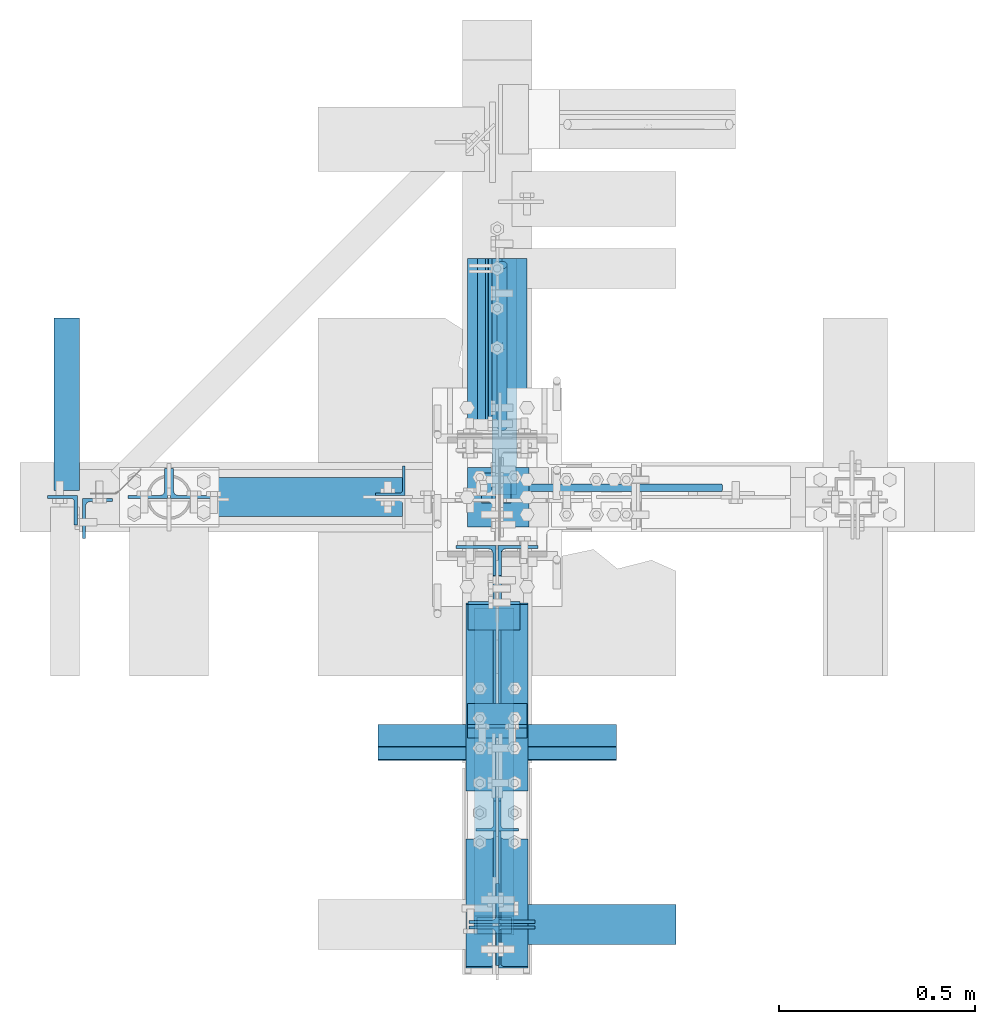
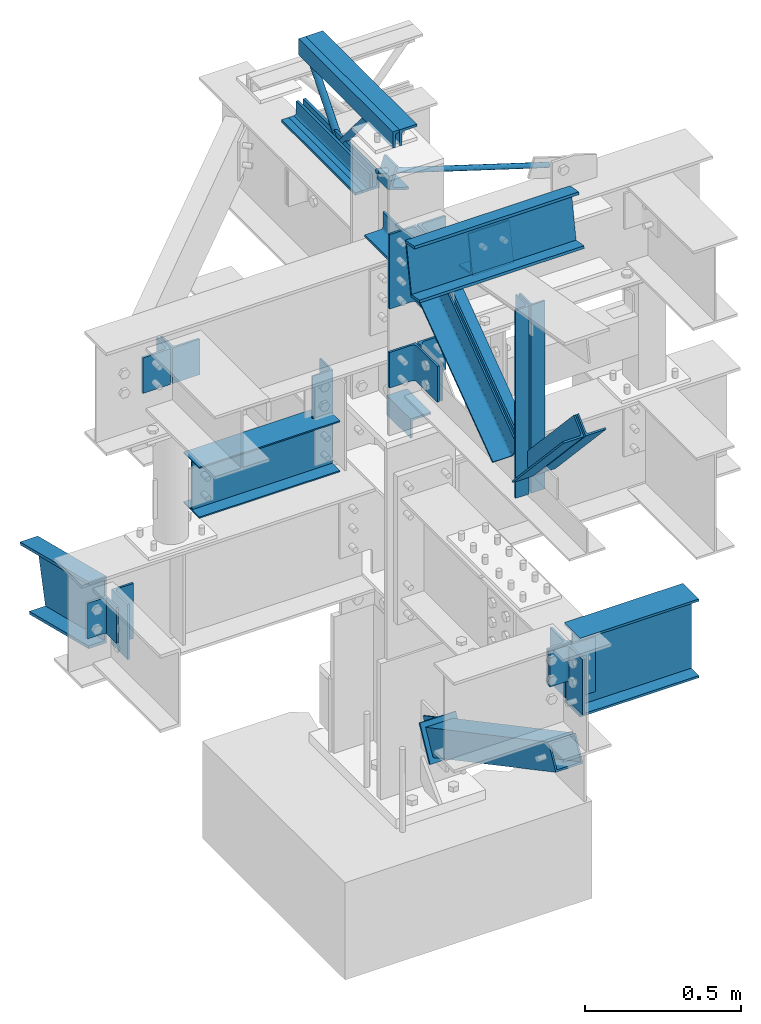
# Not in any storey, part 2 of 7: 31 members, 4 beams, 15 elements without a shape of their own.
"""IFC2X3 building model written with IfcOpenShell, lengths in inches."""

from ifc_helpers import new_model, entity, si_unit, converted_unit, frame, frame_2d, origin_with_axes, origin_2d_with_axis, place, context, project, spatial, hollow_rectangle, circle, i_section, l_section, t_section, u_section, transform_2d, derived_profile, extrude, clip, halfspace, source, transform, mapped, material, type_object, type_shapes, element, aggregate, save


model = new_model("IFC2X3")

# Units and contexts
model_context = context("Model", 3, precision=1e-05, world=origin_with_axes())
ifc_project = project(units=[converted_unit("LENGTHUNIT", "INCH", entity("IfcLengthMeasure", 25.4), si_unit("LENGTHUNIT", "METRE", prefix="MILLI"), dimensions=[1, 0, 0, 0, 0, 0, 0]), si_unit("PLANEANGLEUNIT", "RADIAN"), si_unit("MASSUNIT", "GRAM", prefix="KILO"), si_unit("TIMEUNIT", "SECOND"), si_unit("AREAUNIT", "SQUARE_METRE"), si_unit("PRESSUREUNIT", "PASCAL"), si_unit("FORCEUNIT", "NEWTON"), si_unit("THERMODYNAMICTEMPERATUREUNIT", "DEGREE_CELSIUS")], contexts=[model_context])

# Site, building
site_placement = place(None, origin_with_axes())
site = spatial("IfcSite", under=ifc_project, at=site_placement, CompositionType="ELEMENT")
building_placement = place(site_placement, origin_with_axes())
building = spatial("IfcBuilding", under=site, at=building_placement, Name="Building", CompositionType="ELEMENT")

# Assembly, members
assembly_1_placement = place(building_placement, frame((0.0, 0.0, 97.0), z_axis=(0.0, 0.0, -1.0), x_axis=(0.0, 1.0, 0.0)))
assembly_1 = element("IfcElementAssembly", 1, at=assembly_1_placement, inside=building, Name="M_40", PredefinedType="NOTDEFINED")
ifc_material_1 = material()
member_type_1 = type_object("IfcMemberType", Name="L2-1/2x2-1/2x3/8", PredefinedType="USERDEFINED", material=ifc_material_1)
shared_shape_1 = source(origin_with_axes(), model_context, "Body", "SweptSolid", [
    extrude(derived_profile(l_section(Depth=2.5, Width=2.5, Thickness=0.375, FilletRadius=0.3125, at=frame_2d((1.25, 1.25), x_axis=(1.0, 0.0))), transform_2d((0.0, 0.0), x_axis=(-1.0, 0.0), y_axis=(0.0, 1.0))), frame((0.0, 0.0, 0.0), z_axis=(1.0, 0.0, 0.0), x_axis=(0.0, 1.0, 0.0)), (0.0, 0.0, 1.0), 18.6250038146973),
])
type_shapes(member_type_1, [shared_shape_1])
member_1_placement = place(assembly_1_placement, frame((5.375, 0.5, 12.0), z_axis=(0.0, 0.0, -1.0), x_axis=(1.0, 0.0, 0.0)))
member_1 = element("IfcMember", 2, at=member_1_placement, type_object=member_type_1, Name="a33", ObjectType="Member", context=model_context, shape_type="MappedRepresentation", body=[
    mapped(shared_shape_1, transform((0.0, 0.0, 0.0), scale=1.0)),
])
member_type_2 = type_object("IfcMemberType", Name="L2-1/2x2-1/2x3/8", PredefinedType="USERDEFINED", material=ifc_material_1)
shared_shape_2 = source(origin_with_axes(), model_context, "Body", "SweptSolid", [
    extrude(l_section(Depth=2.5, Width=2.5, Thickness=0.375, FilletRadius=0.3125, at=frame_2d((1.25, 1.25), x_axis=(1.0, 0.0))), frame((0.0, 0.0, 0.0), z_axis=(1.0, 0.0, 0.0), x_axis=(0.0, 1.0, 0.0)), (0.0, 0.0, 1.0), 18.6250038146973),
])
type_shapes(member_type_2, [shared_shape_2])
member_2_placement = place(assembly_1_placement, frame((24.0000038146973, -0.5, 12.0), z_axis=(0.0, -1.0, 0.0), x_axis=(-1.0, 0.0, 0.0)))
member_2 = element("IfcMember", 3, at=member_2_placement, type_object=member_type_2, Name="a34", ObjectType="Member", context=model_context, shape_type="MappedRepresentation", body=[
    mapped(shared_shape_2, transform((0.0, 0.0, 0.0), scale=1.0)),
])
member_type_3 = type_object("IfcMemberType", Name="L2-1/2x2-1/2x3/8", PredefinedType="USERDEFINED", material=ifc_material_1)
shared_shape_3 = source(origin_with_axes(), model_context, "Body", "SweptSolid", [
    extrude(l_section(Depth=2.5, Width=2.5, Thickness=0.375, FilletRadius=0.3125, at=frame_2d((1.25, 1.25), x_axis=(1.0, 0.0))), frame((0.0, 0.0, 0.0), z_axis=(1.0, 0.0, 0.0), x_axis=(0.0, 1.0, 0.0)), (0.0, 0.0, 1.0), 23.7500038146973),
])
type_shapes(member_type_3, [shared_shape_3])
member_3_placement = place(assembly_1_placement, frame((0.25, 0.5, 0.0), z_axis=(0.0, 0.0, 1.0), x_axis=(1.0, 0.0, 0.0)))
member_3 = element("IfcMember", 4, at=member_3_placement, type_object=member_type_3, Name="a32", ObjectType="Member", context=model_context, shape_type="MappedRepresentation", body=[
    mapped(shared_shape_3, transform((0.0, 0.0, 0.0), scale=1.0)),
])
member_type_4 = type_object("IfcMemberType", Name="L2-1/2x2-1/2x3/8", PredefinedType="USERDEFINED", material=ifc_material_1)
shared_shape_4 = source(origin_with_axes(), model_context, "Body", "SweptSolid", [
    extrude(derived_profile(l_section(Depth=2.5, Width=2.5, Thickness=0.375, FilletRadius=0.3125, at=frame_2d((1.25, 1.25), x_axis=(1.0, 0.0))), transform_2d((0.0, 0.0), x_axis=(-1.0, 0.0), y_axis=(0.0, 1.0))), frame((0.0, 0.0, 0.0), z_axis=(1.0, 0.0, 0.0), x_axis=(0.0, 1.0, 0.0)), (0.0, 0.0, 1.0), 23.7500038146973),
])
type_shapes(member_type_4, [shared_shape_4])
member_4_placement = place(assembly_1_placement, frame((0.25, -0.5, 0.0), z_axis=(0.0, 0.0, 1.0), x_axis=(1.0, 0.0, 0.0)))
member_4 = element("IfcMember", 5, at=member_4_placement, type_object=member_type_4, Name="a6", ObjectType="Member", context=model_context, shape_type="MappedRepresentation", body=[
    mapped(shared_shape_4, transform((0.0, 0.0, 0.0), scale=1.0)),
])

# Assembly, member
assembly_2_placement = place(building_placement, frame((23.9999999999998, 0.9375, 83.0), z_axis=(0.0, 1.0, 0.0), x_axis=(-0.954479957764932, 0.0, 0.29827505800024)))
assembly_2 = element("IfcElementAssembly", 6, at=assembly_2_placement, inside=building, Name="4-7", PredefinedType="NOTDEFINED")
ifc_material_2 = material()
member_type_5 = type_object("IfcMemberType", Name="RB3/4", PredefinedType="BRACE", material=ifc_material_2)
shared_shape_5 = source(origin_with_axes(), model_context, "Body", "SweptSolid", [
    extrude(circle(Radius=0.375, at=origin_2d_with_axis()), frame((0.0, 0.0, 0.0), z_axis=(1.0, 0.0, 0.0), x_axis=(0.0, 1.0, 0.0)), (0.0, 0.0, 1.0), 26.1446208953857),
])
type_shapes(member_type_5, [shared_shape_5])
member_5_placement = place(assembly_2_placement, frame((1.50000073203523, 0.0, 0.0), z_axis=(0.0, 0.0, -1.0), x_axis=(1.0, 0.0, 0.0)))
member_5 = element("IfcMember", 7, at=member_5_placement, type_object=member_type_5, Name="rb5", ObjectType="Vertical brace", context=model_context, shape_type="MappedRepresentation", body=[
    mapped(shared_shape_5, transform((0.0, 0.0, 0.0), scale=1.0)),
])
aggregate(assembly_2, [member_5])

# Assembly, beam
assembly_3_placement = place(building_placement, frame((0.0, -3.0, 80.0), z_axis=(0.0, 0.0, -1.0), x_axis=(0.0, 1.0, 0.0)))
assembly_3 = element("IfcElementAssembly", 8, at=assembly_3_placement, inside=building, Name="2-9", PredefinedType="NOTDEFINED")
beam_type_1 = type_object("IfcBeamType", Name="L3x3x3/8", PredefinedType="USERDEFINED", material=ifc_material_1)
shared_shape_6 = source(origin_with_axes(), model_context, "Body", "SweptSolid", [
    extrude(derived_profile(l_section(Depth=3.0, Width=3.0, Thickness=0.375, FilletRadius=0.3125, at=frame_2d((1.5, 1.5), x_axis=(1.0, 0.0))), transform_2d((0.0, 0.0), x_axis=(-1.0, 0.0), y_axis=(0.0, 1.0))), frame((0.0, 0.0, 0.0), z_axis=(1.0, 0.0, 0.0), x_axis=(0.0, 1.0, 0.0)), (0.0, 0.0, 1.0), 6.0),
])
type_shapes(beam_type_1, [shared_shape_6])
beam_1_placement = place(assembly_3_placement, frame((0.0, 0.0, 0.0), z_axis=(0.0, 0.0, -1.0), x_axis=(1.0, 0.0, 0.0)))
beam_1 = element("IfcBeam", 9, at=beam_1_placement, type_object=beam_type_1, Name="a27", ObjectType="Member", context=model_context, shape_type="MappedRepresentation", body=[
    mapped(shared_shape_6, transform((0.0, 0.0, 0.0), scale=1.0)),
])
aggregate(assembly_3, [beam_1])

# Assembly, member
assembly_4_placement = place(building_placement, frame((0.0, 0.0, 21.0), z_axis=(0.0, -1.0, 0.0), x_axis=(0.0, 0.0, 1.0)))
assembly_4 = element("IfcElementAssembly", 10, at=assembly_4_placement, inside=building, Name="1-2", PredefinedType="NOTDEFINED")
member_type_6 = type_object("IfcMemberType", Name="L3x3x5/16", PredefinedType="USERDEFINED", material=ifc_material_1)
shared_shape_7 = source(origin_with_axes(), model_context, "Body", "SweptSolid", [
    extrude(derived_profile(l_section(Depth=3.0, Width=3.0, Thickness=0.3125, FilletRadius=0.3125, at=frame_2d((1.5, 1.5), x_axis=(1.0, 0.0))), transform_2d((0.0, 0.0), x_axis=(-1.0, 0.0), y_axis=(0.0, 1.0))), frame((0.0, 0.0, 0.0), z_axis=(1.0, 0.0, 0.0), x_axis=(0.0, 1.0, 0.0)), (0.0, 0.0, 1.0), 6.0),
])
type_shapes(member_type_6, [shared_shape_7])
member_6_placement = place(assembly_4_placement, frame((33.5, -0.207499995827675, -3.0), z_axis=(0.0, -1.0, 0.0), x_axis=(0.0, 0.0, 1.0)))
member_6 = element("IfcMember", 11, at=member_6_placement, type_object=member_type_6, Name="a29", ObjectType="Column", context=model_context, shape_type="MappedRepresentation", body=[
    mapped(shared_shape_7, transform((0.0, 0.0, 0.0), scale=1.0)),
])
aggregate(assembly_4, [member_6])

assembly_5_placement = place(building_placement, frame((0.0, 0.0, 54.5), z_axis=(0.0, -1.0, 0.0), x_axis=(0.0, 0.0, 1.0)))
assembly_5 = element("IfcElementAssembly", 12, at=assembly_5_placement, inside=building, Name="1-3", PredefinedType="NOTDEFINED")
member_type_7 = type_object("IfcMemberType", Name="L3-1/2x3x3/8", PredefinedType="USERDEFINED", material=ifc_material_1)
shared_shape_8 = source(origin_with_axes(), model_context, "Body", "SweptSolid", [
    extrude(l_section(Depth=3.5, Width=3.0, Thickness=0.375, FilletRadius=0.4375, at=frame_2d((1.5, 1.75), x_axis=(1.0, 0.0))), frame((0.0, 0.0, 0.0), z_axis=(1.0, 0.0, 0.0), x_axis=(0.0, 1.0, 0.0)), (0.0, 0.0, 1.0), 3.0),
])
type_shapes(member_type_7, [shared_shape_8])
member_7_placement = place(assembly_5_placement, frame((34.3969296478214, 1.56886904721182, -2.43749999809271), z_axis=(0.952395799643279, -0.304864299028012, 0.0), x_axis=(0.0, 0.0, 1.0)))
member_7 = element("IfcMember", 13, at=member_7_placement, type_object=member_type_7, Name="a24", ObjectType="Column", context=model_context, shape_type="MappedRepresentation", body=[
    mapped(shared_shape_8, transform((0.0, 0.0, 0.0), scale=1.0)),
])
aggregate(assembly_5, [member_7])

assembly_6_placement = place(building_placement, frame((0.0, 0.0, 46.0), z_axis=(0.0, 0.0, 1.0), x_axis=(-1.0, 0.0, 0.0)))
assembly_6 = element("IfcElementAssembly", 14, at=assembly_6_placement, inside=building, Name="2-4", PredefinedType="NOTDEFINED")
member_type_8 = type_object("IfcMemberType", Name="L4x3x5/16", PredefinedType="USERDEFINED", material=ifc_material_1)
shared_shape_9 = source(origin_with_axes(), model_context, "Body", "SweptSolid", [
    extrude(l_section(Depth=4.0, Width=3.0, Thickness=0.3125, FilletRadius=0.4375, at=frame_2d((1.5, 2.0), x_axis=(1.0, 0.0))), frame((0.0, 0.0, 0.0), z_axis=(1.0, 0.0, 0.0), x_axis=(0.0, 1.0, 0.0)), (0.0, 0.0, 1.0), 8.5),
])
type_shapes(member_type_8, [shared_shape_9])
member_8_placement = place(assembly_6_placement, frame((41.7179999947548, 0.14750000834465, -4.75), z_axis=(0.0, 1.0, 0.0), x_axis=(0.0, 0.0, -1.0)))
member_8 = element("IfcMember", 15, at=member_8_placement, type_object=member_type_8, Name="a1", ObjectType="Beam", context=model_context, shape_type="MappedRepresentation", body=[
    mapped(shared_shape_9, transform((0.0, 0.0, 0.0), scale=1.0)),
])
aggregate(assembly_6, [member_8])

# Assembly, beam
assembly_7_placement = place(building_placement, frame((-9.25, 0.0, 57.0), z_axis=(0.0, 0.0, 1.0), x_axis=(-1.0, 0.0, 0.0)))
assembly_7 = element("IfcElementAssembly", 16, at=assembly_7_placement, inside=building, Name="3-13", PredefinedType="NOTDEFINED")
ifc_material_3 = material()
beam_type_2 = type_object("IfcBeamType", Name="W8x10", PredefinedType="BEAM", material=ifc_material_3)
shared_shape_10 = source(origin_with_axes(), model_context, "Body", "SweptSolid", [
    extrude(i_section(OverallWidth=3.94, OverallDepth=7.89, WebThickness=0.17, FlangeThickness=0.205, at=frame_2d((0.0, -3.945), x_axis=(1.0, 0.0))), frame((0.0, 0.0, 0.0), z_axis=(1.0, 0.0, 0.0), x_axis=(0.0, 1.0, 0.0)), (0.0, 0.0, 1.0), 20.5),
])
type_shapes(beam_type_2, [shared_shape_10])
beam_2_placement = place(assembly_7_placement, frame((0.25, 0.0, 0.0), z_axis=(0.0, 0.0, 1.0), x_axis=(1.0, 0.0, 0.0)))
beam_2 = element("IfcBeam", 17, at=beam_2_placement, type_object=beam_type_2, Name="w8", ObjectType="Beam", context=model_context, shape_type="MappedRepresentation", body=[
    mapped(shared_shape_10, transform((0.0, 0.0, 0.0), scale=1.0)),
])
aggregate(assembly_7, [beam_2])

# Assembly, member
assembly_8_placement = place(building_placement, frame((-9.25, 0.0, 50.0), z_axis=(-1.0, 0.0, 0.0), x_axis=(0.0, 0.0, 1.0)))
assembly_8 = element("IfcElementAssembly", 18, at=assembly_8_placement, inside=building, Name="4-5", PredefinedType="NOTDEFINED")
member_type_9 = type_object("IfcMemberType", Name="L3x3x1/4", PredefinedType="USERDEFINED", material=ifc_material_1)
shared_shape_11 = source(origin_with_axes(), model_context, "Body", "SweptSolid", [
    extrude(l_section(Depth=3.0, Width=3.0, Thickness=0.25, FilletRadius=0.3125, at=frame_2d((1.5, 1.5), x_axis=(1.0, 0.0))), frame((0.0, 0.0, 0.0), z_axis=(1.0, 0.0, 0.0), x_axis=(0.0, 1.0, 0.0)), (0.0, 0.0, 1.0), 13.5),
])
type_shapes(member_type_9, [shared_shape_11])
member_9_placement = place(assembly_8_placement, frame((13.5, 0.156249999999994, 0.0), z_axis=(0.0, 1.0, 0.0), x_axis=(-1.0, 0.0, 0.0)))
member_9 = element("IfcMember", 19, at=member_9_placement, type_object=member_type_9, Name="a36", ObjectType="Column", context=model_context, shape_type="MappedRepresentation", body=[
    mapped(shared_shape_11, transform((0.0, 0.0, 0.0), scale=1.0)),
])
aggregate(assembly_8, [member_9])

# Assembly, members
assembly_9_placement = place(building_placement, frame((-42.0, 0.0, 43.0), z_axis=(0.0, 0.242535628120103, 0.970142499374389), x_axis=(0.0, 0.970142499374388, -0.242535628120103)))
assembly_9 = element("IfcElementAssembly", 20, at=assembly_9_placement, inside=building, Name="3-8", PredefinedType="NOTDEFINED")
member_type_10 = type_object("IfcMemberType", Name="L3x3x5/16", PredefinedType="USERDEFINED", material=ifc_material_1)
shared_shape_12 = source(origin_with_axes(), model_context, "Body", "SweptSolid", [
    extrude(derived_profile(l_section(Depth=3.0, Width=3.0, Thickness=0.3125, FilletRadius=0.3125, at=frame_2d((1.5, 1.5), x_axis=(1.0, 0.0))), transform_2d((0.0, 0.0), x_axis=(-1.0, 0.0), y_axis=(0.0, 1.0))), frame((0.0, 0.0, 0.0), z_axis=(1.0, 0.0, 0.0), x_axis=(0.0, 1.0, 0.0)), (0.0, 0.0, 1.0), 5.5),
])
type_shapes(member_type_10, [shared_shape_12])
member_10_placement = place(assembly_9_placement, frame((0.848874774117084, 0.239999994635582, -2.62241641770861), z_axis=(0.0, 1.0, 0.0), x_axis=(0.242535628120103, 0.0, -0.970142499374389)))
member_10 = element("IfcMember", 21, at=member_10_placement, type_object=member_type_10, Name="a2", ObjectType="Beam", context=model_context, shape_type="MappedRepresentation", body=[
    mapped(shared_shape_12, transform((0.0, 0.0, 0.0), scale=1.0)),
])
ifc_material_4 = material()
member_type_11 = type_object("IfcMemberType", Name="C10x15.3", PredefinedType="USERDEFINED", material=ifc_material_4)
shared_shape_13 = source(origin_with_axes(), model_context, "Body", "Clipping", [
    clip(extrude(u_section(Depth=10.0, FlangeWidth=2.6, WebThickness=0.24, FlangeThickness=0.436, at=frame_2d((1.3, -5.0), x_axis=(1.0, 0.0))), frame((0.0, 0.0, 0.0), z_axis=(1.0, 0.0, 0.0), x_axis=(0.0, 1.0, 0.0)), (0.0, 0.0, 1.0), 17.8453178405762), halfspace(frame((0.0, 0.0, 0.0), z_axis=(-0.97013, 0.0, -0.2426), x_axis=(-0.2426, 0.0, 0.97013)), False)),
])
type_shapes(member_type_11, [shared_shape_13])
member_11_placement = place(assembly_9_placement, frame((0.708658754825592, 0.0, 0.0), z_axis=(0.0, 0.0, 1.0), x_axis=(1.0, 0.0, 0.0)))
member_11 = element("IfcMember", 22, at=member_11_placement, type_object=member_type_11, Name="c1", ObjectType="Beam", context=model_context, shape_type="MappedRepresentation", body=[
    mapped(shared_shape_13, transform((0.0, 0.0, 0.0), scale=1.0)),
])
aggregate(assembly_9, [member_10, member_11])

assembly_10_placement = place(building_placement, frame((0.0, -43.0, 46.0), z_axis=(0.0, 0.0, 1.0), x_axis=(1.0, 0.0, 0.0)))
assembly_10 = element("IfcElementAssembly", 23, at=assembly_10_placement, inside=building, Name="3-6", PredefinedType="NOTDEFINED")
member_type_12 = type_object("IfcMemberType", Name="L4x3x5/16", PredefinedType="USERDEFINED", material=ifc_material_1)
shared_shape_14 = source(origin_with_axes(), model_context, "Body", "SweptSolid", [
    extrude(derived_profile(l_section(Depth=4.0, Width=3.0, Thickness=0.3125, FilletRadius=0.4375, at=frame_2d((1.5, 2.0), x_axis=(1.0, 0.0))), transform_2d((0.0, 0.0), x_axis=(-1.0, 0.0), y_axis=(0.0, 1.0))), frame((0.0, 0.0, 0.0), z_axis=(1.0, 0.0, 0.0), x_axis=(0.0, 1.0, 0.0)), (0.0, 0.0, 1.0), 5.5),
])
type_shapes(member_type_12, [shared_shape_14])
member_12_placement = place(assembly_10_placement, frame((0.1875, -0.117499999701977, -7.25), z_axis=(0.0, -1.0, 0.0), x_axis=(0.0, 0.0, 1.0)))
member_12 = element("IfcMember", 24, at=member_12_placement, type_object=member_type_12, Name="a12", ObjectType="Beam", context=model_context, shape_type="MappedRepresentation", body=[
    mapped(shared_shape_14, transform((0.0, 0.0, 0.0), scale=1.0)),
])
member_13_placement = place(assembly_10_placement, frame((0.1875, 0.117499999701977, -1.75), z_axis=(0.0, 1.0, 0.0), x_axis=(0.0, 0.0, -1.0)))
member_13 = element("IfcMember", 25, at=member_13_placement, type_object=member_type_12, Name="a12", ObjectType="Beam", context=model_context, shape_type="MappedRepresentation", body=[
    mapped(shared_shape_14, transform((0.0, 0.0, 0.0), scale=1.0)),
])

assembly_11_placement = place(building_placement, frame((-33.0, 0.0, 77.0), z_axis=(0.0, 0.0, 1.0), x_axis=(0.0, -1.0, 0.0)))
assembly_11 = element("IfcElementAssembly", 26, at=assembly_11_placement, inside=building, Name="3-10", PredefinedType="NOTDEFINED")
member_14_placement = place(assembly_11_placement, frame((0.125, -0.144999995827675, -7.25), z_axis=(0.0, -1.0, 0.0), x_axis=(0.0, 0.0, 1.0)))
member_14 = element("IfcMember", 27, at=member_14_placement, type_object=member_type_12, Name="a31", ObjectType="Beam", context=model_context, shape_type="MappedRepresentation", body=[
    mapped(shared_shape_14, transform((0.0, 0.0, 0.0), scale=1.0)),
])
member_15_placement = place(assembly_11_placement, frame((0.125, 0.144999995827675, -1.75), z_axis=(0.0, 1.0, 0.0), x_axis=(0.0, 0.0, -1.0)))
member_15 = element("IfcMember", 28, at=member_15_placement, type_object=member_type_12, Name="a31", ObjectType="Beam", context=model_context, shape_type="MappedRepresentation", body=[
    mapped(shared_shape_14, transform((0.0, 0.0, 0.0), scale=1.0)),
])
aggregate(assembly_11, [member_14, member_15])

# Beam
beam_type_3 = type_object("IfcBeamType", Name="W12x19", PredefinedType="BEAM", material=ifc_material_3)
shared_shape_15 = source(origin_with_axes(), model_context, "Body", "SweptSolid", [
    extrude(i_section(OverallWidth=4.005, OverallDepth=12.16, WebThickness=0.235, FlangeThickness=0.35, at=frame_2d((0.0, -6.08), x_axis=(1.0, 0.0))), frame((0.0, 0.0, 0.0), z_axis=(1.0, 0.0, 0.0), x_axis=(0.0, 1.0, 0.0)), (0.0, 0.0, 1.0), 17.3125),
])
type_shapes(beam_type_3, [shared_shape_15])
beam_3_placement = place(assembly_10_placement, frame((0.6875, 0.0, 0.0), z_axis=(0.0, 0.0, 1.0), x_axis=(1.0, 0.0, 0.0)))
beam_3 = element("IfcBeam", 29, at=beam_3_placement, type_object=beam_type_3, Name="w15", ObjectType="Beam", context=model_context, shape_type="MappedRepresentation", body=[
    mapped(shared_shape_15, transform((0.0, 0.0, 0.0), scale=1.0)),
])

aggregate(assembly_10, [member_12, member_13, beam_3])

# Assembly, members
assembly_12_placement = place(building_placement, frame((0.0, -43.0, 46.0), z_axis=(0.0, 0.0, 1.0), x_axis=(-1.0, 0.0, 0.0)))
assembly_12 = element("IfcElementAssembly", 30, at=assembly_12_placement, inside=building, Name="3-5", PredefinedType="NOTDEFINED")
member_type_13 = type_object("IfcMemberType", Name="L4x4x5/16", PredefinedType="USERDEFINED", material=ifc_material_1)
shared_shape_16 = source(origin_with_axes(), model_context, "Body", "SweptSolid", [
    extrude(derived_profile(l_section(Depth=4.0, Width=4.0, Thickness=0.3125, FilletRadius=0.375, at=frame_2d((2.0, 2.0), x_axis=(1.0, 0.0))), transform_2d((0.0, 0.0), x_axis=(-1.0, 0.0), y_axis=(0.0, 1.0))), frame((0.0, 0.0, 0.0), z_axis=(1.0, 0.0, 0.0), x_axis=(0.0, 1.0, 0.0)), (0.0, 0.0, 1.0), 8.5),
])
type_shapes(member_type_13, [shared_shape_16])
member_16_placement = place(assembly_12_placement, frame((0.1875, -0.127499997615814, -10.25), z_axis=(0.0, -1.0, 0.0), x_axis=(0.0, 0.0, 1.0)))
member_16 = element("IfcMember", 31, at=member_16_placement, type_object=member_type_13, Name="a9", ObjectType="Beam", context=model_context, shape_type="MappedRepresentation", body=[
    mapped(shared_shape_16, transform((0.0, 0.0, 0.0), scale=1.0)),
])
member_17_placement = place(assembly_12_placement, frame((0.1875, 0.127499997615814, -1.75), z_axis=(0.0, 1.0, 0.0), x_axis=(0.0, 0.0, -1.0)))
member_17 = element("IfcMember", 32, at=member_17_placement, type_object=member_type_13, Name="a9", ObjectType="Beam", context=model_context, shape_type="MappedRepresentation", body=[
    mapped(shared_shape_16, transform((0.0, 0.0, 0.0), scale=1.0)),
])
aggregate(assembly_12, [member_16, member_17])

assembly_13_placement = place(building_placement, frame((-0.302501678466797, -6.35499954223631, 7.97817420959473), z_axis=(0.0, 0.470283939984076, 0.882515164624979), x_axis=(0.0, -0.882515164624978, 0.470283939984076)))
assembly_13 = element("IfcElementAssembly", 33, at=assembly_13_placement, inside=building, Name="4-6", PredefinedType="NOTDEFINED")
ifc_material_5 = material()
member_type_14 = type_object("IfcMemberType", Name="WT4x9", PredefinedType="BRACE", material=ifc_material_5)
shared_shape_17 = source(origin_with_axes(), model_context, "Body", "SweptSolid", [
    extrude(t_section(Depth=4.07, FlangeWidth=5.25, WebThickness=0.23, FlangeThickness=0.33, at=frame_2d((0.0, -2.035), x_axis=(1.0, 0.0))), frame((0.0, 0.0, 0.0), z_axis=(1.0, 0.0, 0.0), x_axis=(0.0, 1.0, 0.0)), (0.0, 0.0, 1.0), 5.50000143051147),
])
type_shapes(member_type_14, [shared_shape_17])
member_18_placement = place(assembly_13_placement, frame((6.49234243351773, 0.0, 2.75002784669811), z_axis=(1.0, 0.0, 0.0), x_axis=(0.0, 0.0, -1.0)))
member_18 = element("IfcMember", 34, at=member_18_placement, type_object=member_type_14, Name="wt1", ObjectType="Vertical brace", context=model_context, shape_type="MappedRepresentation", body=[
    mapped(shared_shape_17, transform((0.0, 0.0, 0.0), scale=1.0)),
])
ifc_material_6 = material()
member_type_15 = type_object("IfcMemberType", Name="TS4x4x1/4", PredefinedType="BRACE", material=ifc_material_6)
shared_shape_18 = source(origin_with_axes(), model_context, "Body", "SweptSolid", [
    extrude(hollow_rectangle(XDim=4.0, YDim=4.0, WallThickness=0.25, at=origin_2d_with_axis()), frame((0.0, 0.0, 0.0), z_axis=(1.0, 0.0, 0.0), x_axis=(0.0, 1.0, 0.0)), (0.0, 0.0, 1.0), 35.1264915466309),
])
type_shapes(member_type_15, [shared_shape_18])
member_19_placement = place(assembly_13_placement, frame((6.49999999999999, 0.0, 0.0), z_axis=(0.0, 0.0, 1.0), x_axis=(1.0, 0.0, 0.0)))
member_19 = element("IfcMember", 35, at=member_19_placement, type_object=member_type_15, Name="ts5", ObjectType="Vertical brace", context=model_context, shape_type="MappedRepresentation", body=[
    mapped(shared_shape_18, transform((0.0, 0.0, 0.0), scale=1.0)),
])
aggregate(assembly_13, [member_18, member_19])

assembly_14_placement = place(building_placement, frame((0.0, -47.9999999999999, 94.0), z_axis=(0.0, 0.17437043319647, 0.984680126755321), x_axis=(0.0, 0.98468012675532, -0.17437043319647)))
assembly_14 = element("IfcElementAssembly", 36, at=assembly_14_placement, inside=building, Name="4-8", PredefinedType="NOTDEFINED")
member_type_16 = type_object("IfcMemberType", Name="L4x3x5/16", PredefinedType="USERDEFINED", material=ifc_material_1)
shared_shape_19 = source(origin_with_axes(), model_context, "Body", "SweptSolid", [
    extrude(l_section(Depth=4.0, Width=3.0, Thickness=0.3125, FilletRadius=0.4375, at=frame_2d((1.5, 2.0), x_axis=(1.0, 0.0))), frame((0.0, 0.0, 0.0), z_axis=(1.0, 0.0, 0.0), x_axis=(0.0, 1.0, 0.0)), (0.0, 0.0, 1.0), 11.5),
])
type_shapes(member_type_16, [shared_shape_19])
member_20_placement = place(assembly_14_placement, frame((45.9081465219534, -0.107503354549408, -11.9277075718198), z_axis=(0.0, -1.0, 0.0), x_axis=(-0.17437043319647, 0.0, 0.984680126755321)))
member_20 = element("IfcMember", 37, at=member_20_placement, type_object=member_type_16, Name="a16", ObjectType="Beam", context=model_context, shape_type="MappedRepresentation", body=[
    mapped(shared_shape_19, transform((0.0, 0.0, 0.0), scale=1.0)),
])
member_21_placement = place(assembly_14_placement, frame((43.9028865401939, 0.122502744197844, -0.603886114133672), z_axis=(0.0, 1.0, 0.0), x_axis=(0.17437043319647, 0.0, -0.984680126755321)))
member_21 = element("IfcMember", 38, at=member_21_placement, type_object=member_type_16, Name="a16", ObjectType="Beam", context=model_context, shape_type="MappedRepresentation", body=[
    mapped(shared_shape_19, transform((0.0, 0.0, 0.0), scale=1.0)),
])
member_type_17 = type_object("IfcMemberType", Name="L6x3-1/2x5/16", PredefinedType="USERDEFINED", material=ifc_material_1)
shared_shape_20 = source(origin_with_axes(), model_context, "Body", "SweptSolid", [
    extrude(derived_profile(l_section(Depth=6.0, Width=3.5, Thickness=0.3125, FilletRadius=0.5, at=frame_2d((1.75, 3.0), x_axis=(1.0, 0.0))), transform_2d((0.0, 0.0), x_axis=(-1.0, 0.0), y_axis=(0.0, 1.0))), frame((0.0, 0.0, 0.0), z_axis=(1.0, 0.0, 0.0), x_axis=(0.0, 1.0, 0.0)), (0.0, 0.0, 1.0), 6.0),
])
type_shapes(member_type_17, [shared_shape_20])
member_22_placement = place(assembly_14_placement, frame((24.0000007250116, 3.0, 0.687500208160415), z_axis=(0.0, 0.0, 1.0), x_axis=(0.0, -1.0, 0.0)))
member_22 = element("IfcMember", 39, at=member_22_placement, type_object=member_type_17, Name="a25", ObjectType="Beam", context=model_context, shape_type="MappedRepresentation", body=[
    mapped(shared_shape_20, transform((0.0, 0.0, 0.0), scale=1.0)),
])
member_type_18 = type_object("IfcMemberType", Name="L6x4x5/16", PredefinedType="USERDEFINED", material=ifc_material_1)
shared_shape_21 = source(origin_with_axes(), model_context, "Body", "SweptSolid", [
    extrude(l_section(Depth=6.0, Width=4.0, Thickness=0.3125, FilletRadius=0.5, at=frame_2d((2.0, 3.0), x_axis=(1.0, 0.0))), frame((0.0, 0.0, 0.0), z_axis=(1.0, 0.0, 0.0), x_axis=(0.0, 1.0, 0.0)), (0.0, 0.0, 1.0), 5.5),
])
type_shapes(member_type_18, [shared_shape_21])
member_23_placement = place(assembly_14_placement, frame((48.0431350813066, 0.115000002086163, -23.9267525398229), z_axis=(-0.98468012675532, 0.0, -0.17437043319647), x_axis=(-0.17437043319647, 0.0, 0.984680126755321)))
member_23 = element("IfcMember", 40, at=member_23_placement, type_object=member_type_18, Name="a26", ObjectType="Beam", context=model_context, shape_type="MappedRepresentation", body=[
    mapped(shared_shape_21, transform((0.0, 0.0, 0.0), scale=1.0)),
])
member_24_placement = place(assembly_14_placement, frame((47.084097698726, -0.115000002086165, -18.5110118426687), z_axis=(-0.98468012675532, 0.0, -0.17437043319647), x_axis=(0.17437043319647, 0.0, -0.984680126755321)))
member_24 = element("IfcMember", 41, at=member_24_placement, type_object=member_type_18, Name="a26", ObjectType="Beam", context=model_context, shape_type="MappedRepresentation", body=[
    mapped(shared_shape_21, transform((0.0, 0.0, 0.0), scale=1.0)),
])
member_type_19 = type_object("IfcMemberType", Name="L3x3x1/4", PredefinedType="USERDEFINED", material=ifc_material_1)
shared_shape_22 = source(origin_with_axes(), model_context, "Body", "SweptSolid", [
    extrude(derived_profile(l_section(Depth=3.0, Width=3.0, Thickness=0.25, FilletRadius=0.3125, at=frame_2d((1.5, 1.5), x_axis=(1.0, 0.0))), transform_2d((0.0, 0.0), x_axis=(-1.0, 0.0), y_axis=(0.0, 1.0))), frame((0.0, 0.0, 0.0), z_axis=(1.0, 0.0, 0.0), x_axis=(0.0, 1.0, 0.0)), (0.0, 0.0, 1.0), 23.2499942779541),
])
type_shapes(member_type_19, [shared_shape_22])
member_25_placement = place(assembly_14_placement, frame((23.3610050291526, -0.125, -25.3745518841465), z_axis=(0.0, -1.0, 0.0), x_axis=(0.691079008354412, 0.0, 0.72277922231611)))
member_25 = element("IfcMember", 42, at=member_25_placement, type_object=member_type_19, Name="a4", ObjectType="Beam", context=model_context, shape_type="MappedRepresentation", body=[
    mapped(shared_shape_22, transform((0.0, 0.0, 0.0), scale=1.0)),
])
member_26_placement = place(assembly_14_placement, frame((39.4285880667948, 0.125, -8.56993931105693), z_axis=(0.0, 1.0, 0.0), x_axis=(-0.691079008354409, 0.0, -0.722779222316112)))
member_26 = element("IfcMember", 43, at=member_26_placement, type_object=member_type_19, Name="a4", ObjectType="Beam", context=model_context, shape_type="MappedRepresentation", body=[
    mapped(shared_shape_22, transform((0.0, 0.0, 0.0), scale=1.0)),
])
member_type_20 = type_object("IfcMemberType", Name="L3x2x1/4", PredefinedType="USERDEFINED", material=ifc_material_1)
shared_shape_23 = source(origin_with_axes(), model_context, "Body", "SweptSolid", [
    extrude(l_section(Depth=3.0, Width=2.0, Thickness=0.25, FilletRadius=0.3125, at=frame_2d((1.0, 1.5), x_axis=(1.0, 0.0))), frame((0.0, 0.0, 0.0), z_axis=(1.0, 0.0, 0.0), x_axis=(0.0, 1.0, 0.0)), (0.0, 0.0, 1.0), 29.0),
])
type_shapes(member_type_20, [shared_shape_23])
member_27_placement = place(assembly_14_placement, frame((19.8574554988699, -0.134998321533203, -29.3839910943416), z_axis=(0.98468012675532, 0.0, 0.17437043319647), x_axis=(-0.17437043319647, 0.0, 0.984680126755321)))
member_27 = element("IfcMember", 44, at=member_27_placement, type_object=member_type_20, Name="a21", ObjectType="Beam", context=model_context, shape_type="MappedRepresentation", body=[
    mapped(shared_shape_23, transform((0.0, 0.0, 0.0), scale=1.0)),
])
member_28_placement = place(assembly_14_placement, frame((14.8007129361722, 0.134998321533203, -0.828267418437292), z_axis=(0.98468012675532, 0.0, 0.17437043319647), x_axis=(0.17437043319647, 0.0, -0.984680126755321)))
member_28 = element("IfcMember", 45, at=member_28_placement, type_object=member_type_20, Name="a21", ObjectType="Beam", context=model_context, shape_type="MappedRepresentation", body=[
    mapped(shared_shape_23, transform((0.0, 0.0, 0.0), scale=1.0)),
])
member_type_21 = type_object("IfcMemberType", Name="L3x3x1/4", PredefinedType="USERDEFINED", material=ifc_material_1)
shared_shape_24 = source(origin_with_axes(), model_context, "Body", "SweptSolid", [
    extrude(derived_profile(l_section(Depth=3.0, Width=3.0, Thickness=0.25, FilletRadius=0.3125, at=frame_2d((1.5, 1.5), x_axis=(1.0, 0.0))), transform_2d((0.0, 0.0), x_axis=(-1.0, 0.0), y_axis=(0.0, 1.0))), frame((0.0, 0.0, 0.0), z_axis=(1.0, 0.0, 0.0), x_axis=(0.0, 1.0, 0.0)), (0.0, 0.0, 1.0), 18.8750019073486),
])
type_shapes(member_type_21, [shared_shape_24])
member_29_placement = place(assembly_14_placement, frame((3.24754149855325, -0.125, -14.8378072761302), z_axis=(0.0, -1.0, 0.0), x_axis=(0.79698579420595, 0.0, -0.603998049528234)))
member_29 = element("IfcMember", 46, at=member_29_placement, type_object=member_type_21, Name="a30", ObjectType="Beam", context=model_context, shape_type="MappedRepresentation", body=[
    mapped(shared_shape_24, transform((0.0, 0.0, 0.0), scale=1.0)),
])
member_30_placement = place(assembly_14_placement, frame((18.2906509515737, 0.125, -26.2382717407428), z_axis=(0.0, 1.0, 0.0), x_axis=(-0.796985794205948, 0.0, 0.603998049528234)))
member_30 = element("IfcMember", 47, at=member_30_placement, type_object=member_type_21, Name="a30", ObjectType="Beam", context=model_context, shape_type="MappedRepresentation", body=[
    mapped(shared_shape_24, transform((0.0, 0.0, 0.0), scale=1.0)),
])
aggregate(assembly_14, [member_20, member_22, member_23, member_21, member_25, member_26, member_27, member_28, member_29, member_30, member_24])

# Assembly, beam
assembly_15_placement = place(building_placement, frame((-12.0, -24.2477970123291, 90.4920806884765), z_axis=(0.0, -0.174370009636802, -0.984680201760582), x_axis=(1.0, 0.0, 0.0)))
assembly_15 = element("IfcElementAssembly", 48, at=assembly_15_placement, inside=building, Name="4-9", PredefinedType="NOTDEFINED")
beam_type_4 = type_object("IfcBeamType", Name="C8x11.5", PredefinedType="BEAM", material=ifc_material_4)
shared_shape_25 = source(origin_with_axes(), model_context, "Body", "SweptSolid", [
    extrude(derived_profile(u_section(Depth=8.0, FlangeWidth=2.26, WebThickness=0.22, FlangeThickness=0.39, at=frame_2d((1.13, -4.0), x_axis=(1.0, 0.0))), transform_2d((0.0, 0.0), x_axis=(-1.0, 0.0), y_axis=(0.0, 1.0))), frame((0.0, 0.0, 0.0), z_axis=(1.0, 0.0, 0.0), x_axis=(0.0, 1.0, 0.0)), (0.0, 0.0, 1.0), 24.0),
])
type_shapes(beam_type_4, [shared_shape_25])
beam_4_placement = place(assembly_15_placement, origin_with_axes())
beam_4 = element("IfcBeam", 49, at=beam_4_placement, type_object=beam_type_4, Name="c2", ObjectType="Beam", context=model_context, shape_type="MappedRepresentation", body=[
    mapped(shared_shape_25, transform((0.0, 0.0, 0.0), scale=1.0)),
])
aggregate(assembly_15, [beam_4])

# Member
member_31_placement = place(assembly_1_placement, frame((23.4185070188086, 0.497068971505183, 1.55131149292049), z_axis=(0.0, 1.0, 0.0), x_axis=(0.642285189490803, 0.0, 0.766465743109738)))
cartesian_point = entity("IfcCartesianPoint", [0.0, 0.0, 0.0])
ifc_direction = entity("IfcDirection", [0.0, 0.0, 1.0])
member_31 = element("IfcMember", 50, at=member_31_placement, Name="rb2", ObjectType="Member", context=model_context, shape_type="SweptSolid", body=[
    entity("IfcSurfaceCurveSweptAreaSolid", entity("IfcCircleProfileDef", "AREA", None, entity("IfcAxis2Placement2D", entity("IfcCartesianPoint", [0.0, 0.0]), entity("IfcDirection", [1.0, 0.0])), 0.5), entity("IfcAxis2Placement3D", cartesian_point, ifc_direction, entity("IfcDirection", [1.0, 0.0, 0.0])), entity("IfcPolyline", [entity("IfcCartesianPoint", [-0.0454, -0.05412]), entity("IfcCartesianPoint", [1.9215, -11.20844]), entity("IfcCartesianPoint", [1.9183, -11.61735]), entity("IfcCartesianPoint", [1.7879, -11.96562]), entity("IfcCartesianPoint", [1.5227, -12.27681]), entity("IfcCartesianPoint", [1.199, -12.45983]), entity("IfcCartesianPoint", [0.7957, -12.52769]), entity("IfcCartesianPoint", [-10.4979, -12.52762])]), 0.0, 1.0, entity("IfcPlane", entity("IfcAxis2Placement3D", cartesian_point, entity("IfcDirection", [0.0, 1.0, 0.0]), ifc_direction))),
])

aggregate(assembly_1, [member_1, member_2, member_31, member_3, member_4])

save(model, "model.ifc")
